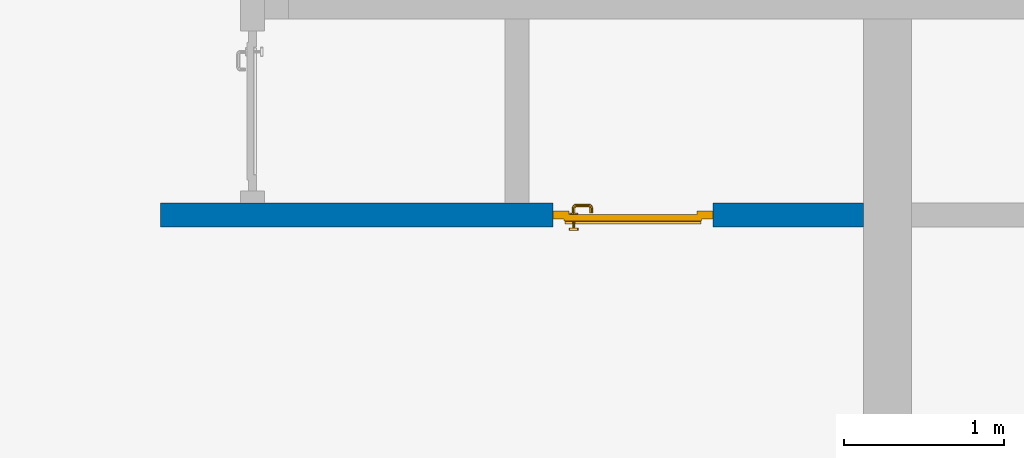
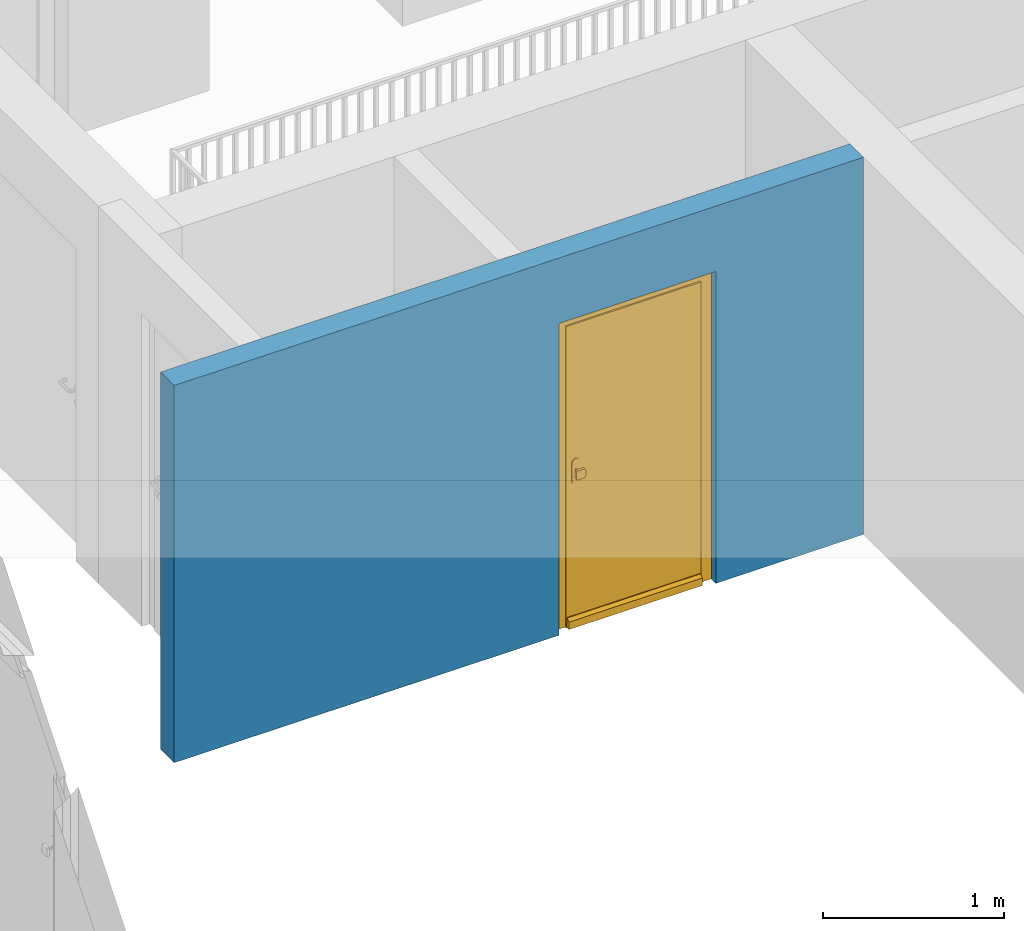
# One storey, part 2 of 54: 1 door, 1 wall, 1 opening.
"""IFC4 building model written with IfcOpenShell, lengths in metres."""

from ifc_helpers import new_model, entity, si_unit, converted_unit, derived_unit, direction, frame, origin_with_axes, place, context, subcontext, project, spatial, polygons, source, transform, mapped, material, type_object, element, fill, save


model = new_model("IFC4")

# Units and contexts
model_context = context("Model", 3, precision=1e-05, world=origin_with_axes(), true_north=direction((0.0, 1.0)))
body_context = subcontext(model_context, "Body", "Model", "MODEL_VIEW")
ifc_project = project(units=[si_unit("LENGTHUNIT", "METRE"), si_unit("AREAUNIT", "SQUARE_METRE"), si_unit("VOLUMEUNIT", "CUBIC_METRE"), converted_unit("PLANEANGLEUNIT", "DEGREE", entity("IfcPlaneAngleMeasure", 0.0174532925199), si_unit("PLANEANGLEUNIT", "RADIAN"), dimensions=[0, 0, 0, 0, 0, 0, 0]), converted_unit("TIMEUNIT", "Year", entity("IfcTimeMeasure", 31556926.0), si_unit("TIMEUNIT", "SECOND"), dimensions=[0, 0, 1, 0, 0, 0, 0]), si_unit("MASSUNIT", "GRAM", prefix="KILO"), si_unit("THERMODYNAMICTEMPERATUREUNIT", "DEGREE_CELSIUS"), si_unit("LUMINOUSINTENSITYUNIT", "LUMEN"), si_unit("ENERGYUNIT", "JOULE", prefix="MEGA"), derived_unit("THERMALCONDUCTANCEUNIT", [(si_unit("POWERUNIT", "WATT"), 1), (si_unit("LENGTHUNIT", "METRE"), -1), (si_unit("THERMODYNAMICTEMPERATUREUNIT", "KELVIN"), -1)]), derived_unit("SPECIFICHEATCAPACITYUNIT", [(si_unit("ENERGYUNIT", "JOULE"), 1), (si_unit("MASSUNIT", "GRAM", prefix="KILO"), -1), (si_unit("THERMODYNAMICTEMPERATUREUNIT", "KELVIN"), -1)]), derived_unit("MASSDENSITYUNIT", [(si_unit("MASSUNIT", "GRAM", prefix="KILO"), 1), (si_unit("VOLUMEUNIT", "CUBIC_METRE"), -1)])], contexts=[model_context])

# Site, building, storey
site_placement = place(None, origin_with_axes())
site = spatial("IfcSite", under=ifc_project, at=site_placement, CompositionType="ELEMENT")
building_placement = place(site_placement, origin_with_axes())
building = spatial("IfcBuilding", under=site, at=building_placement, CompositionType="ELEMENT")
storey_placement = place(building_placement, frame((0.0, 0.0, 9.18), z_axis=(0.0, 0.0, 1.0), x_axis=(1.0, 0.0, 0.0)))
storey = spatial("IfcBuildingStorey", under=building, at=storey_placement, Name="3. Geschoss", CompositionType="ELEMENT", Elevation=9.18)

# Wall, opening, door
ifc_material = material()
wall_type = type_object("IfcWallType", Name="150", PredefinedType="NOTDEFINED")
wall_placement = place(storey_placement, frame((-5.7421993804, -4.12881223104, 0.0), z_axis=(0.0, 0.0, 1.0), x_axis=(1.0, 0.0, 0.0)))
wall = element("IfcWall", 1, at=wall_placement, inside=storey, type_object=wall_type, material=ifc_material, Name="Wand-002", PredefinedType="NOTDEFINED", context=body_context, shape_type="Tessellation", body=[
    polygons([(2.45, 0.15, 2.1), (2.45, 0.15, 0.0), (0.0, 0.15, 0.0), (0.0, 0.15, 2.54), (4.39, 0.15, 2.54), (4.39, 0.15, 0.0), (3.45, 0.15, 0.0), (3.45, 0.15, 2.1), (2.45, 0.05, 0.0), (2.45, 0.0, 2.1), (2.45, 0.0, 0.0), (0.0, 0.0, 0.0), (0.0, 0.0, 2.54), (4.39, 0.0, 2.54), (4.39, 0.0, 0.0), (3.45, 0.05, 0.0), (3.45, 0.0, 0.0), (3.45, 0.0, 2.1)], [[[1, 2, 3, 4, 5, 6, 7, 8]], [[9, 2, 1, 10, 11]], [[2, 9, 11, 12, 3]], [[4, 3, 12, 13]], [[5, 4, 13, 14]], [[14, 15, 6, 5]], [[16, 7, 6, 15, 17]], [[8, 7, 16, 17, 18]], [[1, 8, 18, 10]], [[12, 11, 10, 18, 17, 15, 14, 13]]], closed=True),
])
opening_placement = place(wall_placement, frame((2.95, 0.0, 0.0), z_axis=(0.0, 0.0, 1.0), x_axis=(1.0, 0.0, 0.0)))
opening = element("IfcOpeningElement", 2, at=opening_placement, cuts=wall, context=body_context, identifier="Reference", shape_type="Tessellation", body=[
    polygons([(0.5, 0.05, 0.0), (0.5, 0.05, 2.1), (0.5, -0.001, 2.1), (0.5, -0.001, 0.0), (0.5, 0.151, 0.0), (0.5, 0.151, 2.1), (-0.5, 0.05, 2.1), (-0.5, -0.001, 2.1), (-0.5, 0.151, 2.1), (-0.5, -0.001, 0.0), (-0.5, 0.05, 0.0), (-0.5, 0.151, 0.0)], [[[1, 2, 3, 4]], [[2, 1, 5, 6]], [[7, 8, 3, 2, 6, 9]], [[8, 10, 4, 3]], [[1, 4, 10, 11, 12, 5]], [[6, 5, 12, 9]], [[7, 11, 10, 8]], [[11, 7, 9, 12]]], closed=True),
])
door_type = type_object("IfcDoorType", Name="Eingang 01 1-Fl 26", OperationType="SINGLE_SWING_LEFT", PredefinedType="DOOR")
shared_shape = source(origin_with_axes(), body_context, "Body", "Tessellation", [
    polygons([(-0.5, -0.05, 0.0), (-0.5, -0.05, 2.1), (-0.5, -0.03, 2.1), (-0.5, -0.03, 0.0), (-0.4, -0.05, 0.0), (-0.4, -0.05, 2.0), (-0.1301, -0.05, 2.0), (-0.0001, -0.05, 2.0), (0.4, -0.05, 2.0), (0.4, -0.05, 0.0), (0.5, -0.05, 0.0), (0.5, -0.05, 2.1), (0.5, -0.03, 2.1), (0.5, -0.03, 0.0), (0.4, -0.03, 0.0), (0.4, -0.03, 2.0), (-0.0001, -0.03, 2.0), (-0.1301, -0.03, 2.0), (-0.4, -0.03, 2.0), (-0.4, -0.03, 0.0)], [[[1, 2, 3, 4]], [[1, 5, 6, 7, 8, 9, 10, 11, 12, 2]], [[2, 12, 13, 3]], [[4, 3, 13, 14, 15, 16, 17, 18, 19, 20]], [[5, 1, 4, 20]], [[6, 5, 20, 19]], [[7, 6, 19, 18]], [[8, 7, 18, 17]], [[9, 8, 17, 16]], [[10, 9, 16, 15]], [[11, 10, 15, 14]], [[12, 11, 14, 13]]], closed=True),
    polygons([(-0.5, -0.03, 0.0), (-0.5, -0.03, 2.1), (-0.5, 0.0, 2.1), (-0.5, 0.0, 0.0), (-0.43, -0.03, 0.0), (-0.43, -0.03, 2.03), (-0.1001, -0.03, 2.03), (-0.0301, -0.03, 2.03), (0.43, -0.03, 2.03), (0.43, -0.03, 0.0), (0.5, -0.03, 0.0), (0.5, -0.03, 2.1), (0.5, 0.0, 2.1), (0.5, 0.0, 0.0), (0.43, 0.0, 0.0), (0.43, 0.0, 2.03), (-0.0301, 0.0, 2.03), (-0.1001, 0.0, 2.03), (-0.43, 0.0, 2.03), (-0.43, 0.0, 0.0)], [[[1, 2, 3, 4]], [[1, 5, 6, 7, 8, 9, 10, 11, 12, 2]], [[2, 12, 13, 3]], [[4, 3, 13, 14, 15, 16, 17, 18, 19, 20]], [[5, 1, 4, 20]], [[6, 5, 20, 19]], [[7, 6, 19, 18]], [[8, 7, 18, 17]], [[9, 8, 17, 16]], [[10, 9, 16, 15]], [[11, 10, 15, 14]], [[12, 11, 14, 13]]], closed=True),
    polygons([(-0.43, 0.01, 0.0), (-0.43, 0.01, 2.03), (0.43, 0.01, 2.03), (0.43, 0.01, 0.0), (-0.43, -0.03, 0.0), (-0.43, -0.03, 2.03), (0.43, -0.03, 2.03), (0.43, -0.03, 0.0)], [[[1, 2, 3, 4]], [[1, 5, 6, 2]], [[2, 6, 7, 3]], [[3, 7, 8, 4]], [[4, 8, 5, 1]], [[8, 7, 6, 5]]], closed=True),
    polygons([(-0.425, 0.03, 0.0), (-0.425, 0.03, 0.05), (0.425, 0.03, 0.05), (0.425, 0.03, 0.0), (-0.425, 0.01, 0.0), (-0.425, 0.01, 0.07), (-0.425, 0.015, 0.07), (0.425, 0.015, 0.07), (0.425, 0.01, 0.07), (0.425, 0.01, 0.0)], [[[1, 2, 3, 4]], [[1, 5, 6, 7, 2]], [[2, 7, 8, 3]], [[4, 3, 8, 9, 10]], [[5, 1, 4, 10]], [[6, 5, 10, 9]], [[7, 6, 9, 8]]], closed=True),
    polygons([(0.3835, -0.04, 1.0733826859), (0.3835, -0.0399, 1.0733826859), (0.37, -0.0399, 1.077), (0.37, -0.04, 1.077), (0.393382685902, -0.04, 1.0635), (0.393382685902, -0.0399, 1.0635), (0.3835, -0.0301, 1.0733826859), (0.37, -0.0301, 1.077), (0.3565, -0.0399, 1.0733826859), (0.3565, -0.04, 1.0733826859), (0.346617314098, -0.04, 1.0635), (0.343, -0.04, 1.05), (0.346617314098, -0.04, 1.0365), (0.3565, -0.04, 1.0266173141), (0.37, -0.04, 1.023), (0.3835, -0.04, 1.0266173141), (0.393382685902, -0.04, 1.0365), (0.397, -0.04, 1.05), (0.397, -0.0399, 1.05), (0.393382685902, -0.0301, 1.0635), (0.3835, -0.03, 1.0733826859), (0.37, -0.03, 1.077), (0.3565, -0.0301, 1.0733826859), (0.346617314098, -0.0399, 1.0635), (0.343, -0.0399, 1.05), (0.346617314098, -0.0399, 1.0365), (0.3565, -0.0399, 1.0266173141), (0.37, -0.0399, 1.023), (0.3835, -0.0399, 1.0266173141), (0.393382685902, -0.0399, 1.0365), (0.397, -0.0301, 1.05), (0.393382685902, -0.03, 1.0635), (0.397, -0.03, 1.05), (0.393382685902, -0.03, 1.0365), (0.3835, -0.03, 1.0266173141), (0.37, -0.03, 1.023), (0.3565, -0.03, 1.0266173141), (0.346617314098, -0.03, 1.0365), (0.343, -0.03, 1.05), (0.346617314098, -0.03, 1.0635), (0.3565, -0.03, 1.0733826859), (0.346617314098, -0.0301, 1.0635), (0.343, -0.0301, 1.05), (0.346617314098, -0.0301, 1.0365), (0.3565, -0.0301, 1.0266173141), (0.37, -0.0301, 1.023), (0.3835, -0.0301, 1.0266173141), (0.393382685902, -0.0301, 1.0365)], [[[1, 2, 3, 4]], [[5, 6, 2, 1]], [[2, 7, 8, 3]], [[4, 3, 9, 10]], [[4, 10, 11, 12, 13, 14, 15, 16, 17, 18, 5, 1]], [[18, 19, 6, 5]], [[6, 20, 7, 2]], [[7, 21, 22, 8]], [[3, 8, 23, 9]], [[10, 9, 24, 11]], [[11, 24, 25, 12]], [[12, 25, 26, 13]], [[13, 26, 27, 14]], [[14, 27, 28, 15]], [[15, 28, 29, 16]], [[16, 29, 30, 17]], [[17, 30, 19, 18]], [[19, 31, 20, 6]], [[20, 32, 21, 7]], [[22, 21, 32, 33, 34, 35, 36, 37, 38, 39, 40, 41]], [[8, 22, 41, 23]], [[9, 23, 42, 24]], [[24, 42, 43, 25]], [[25, 43, 44, 26]], [[26, 44, 45, 27]], [[27, 45, 46, 28]], [[28, 46, 47, 29]], [[29, 47, 48, 30]], [[30, 48, 31, 19]], [[31, 33, 32, 20]], [[48, 34, 33, 31]], [[47, 35, 34, 48]], [[46, 36, 35, 47]], [[45, 37, 36, 46]], [[44, 38, 37, 45]], [[43, 39, 38, 44]], [[42, 40, 39, 43]], [[23, 41, 40, 42]]], closed=True),
    polygons([(0.362532169224, -0.04, 0.959692280177), (0.363279754556, -0.04, 0.961639806549), (0.35655, -0.04, 0.973296083362), (0.346703916638, -0.04, 0.96345), (0.365, -0.04, 0.952886751346), (0.365, -0.04, 0.9544), (0.362532169224, -0.039, 0.959692280177), (0.363279754556, -0.039, 0.961639806549), (0.364624817685, -0.039, 0.965143815798), (0.364624817685, -0.04, 0.965143815798), (0.37, -0.04, 0.967425445323), (0.37, -0.04, 0.9769), (0.346617314098, -0.04, 0.9635), (0.3565, -0.04, 0.973382685902), (0.365, -0.04, 0.95), (0.3431, -0.04, 0.95), (0.365, -0.04, 0.947113248654), (0.365, -0.04, 0.941339745962), (0.365, -0.04, 0.9375), (0.365, -0.039, 0.9375), (0.365, -0.039, 0.941339745962), (0.365, -0.039, 0.947113248654), (0.365, -0.039, 0.95), (0.365, -0.039, 0.952886751346), (0.365, -0.039, 0.9544), (0.347569942042, -0.039, 0.96295), (0.35705, -0.039, 0.972430057958), (0.37, -0.039, 0.9759), (0.37, -0.039, 0.967425445323), (0.375375182315, -0.04, 0.965143815798), (0.376720245444, -0.04, 0.961639806549), (0.38345, -0.04, 0.973296083362), (0.37, -0.04, 0.977), (0.343, -0.04, 0.95), (0.346617314098, -0.0399, 0.9635), (0.3565, -0.0399, 0.973382685902), (0.346703916638, -0.04, 0.93655), (0.35655, -0.04, 0.926703916638), (0.37, -0.04, 0.9231), (0.37, -0.04, 0.9325), (0.366464466094, -0.04, 0.933964466094), (0.366464466094, -0.039, 0.933964466094), (0.37, -0.039, 0.9241), (0.35705, -0.039, 0.927569942042), (0.37, -0.039, 0.9325), (0.347569942042, -0.039, 0.93705), (0.3441, -0.039, 0.95), (0.347483339502, -0.039, 0.963), (0.357, -0.039, 0.972516660498), (0.37, -0.039, 0.976), (0.375375182315, -0.039, 0.965143815798), (0.38295, -0.039, 0.972430057958), (0.376720245444, -0.039, 0.961639806549), (0.377467830776, -0.039, 0.959692280177), (0.377467830776, -0.04, 0.959692280177), (0.375, -0.04, 0.9544), (0.375, -0.04, 0.952886751346), (0.393296083362, -0.04, 0.96345), (0.3835, -0.04, 0.973382685902), (0.37, -0.0399, 0.977), (0.346617314098, -0.04, 0.9365), (0.343, -0.0399, 0.95), (0.346617314098, -0.0301, 0.9635), (0.3565, -0.0301, 0.973382685902), (0.3565, -0.04, 0.926617314098), (0.37, -0.04, 0.923), (0.38345, -0.04, 0.926703916638), (0.375, -0.04, 0.941339745962), (0.375, -0.04, 0.9375), (0.373535533906, -0.04, 0.933964466094), (0.37, -0.039, 0.924), (0.357, -0.039, 0.927483339502), (0.38295, -0.039, 0.927569942042), (0.373535533906, -0.039, 0.933964466094), (0.375, -0.039, 0.9375), (0.375, -0.039, 0.941339745962), (0.347483339502, -0.039, 0.937), (0.344, -0.039, 0.95), (0.347483339502, -0.0389, 0.963), (0.357, -0.0389, 0.972516660498), (0.37, -0.0389, 0.976), (0.383, -0.039, 0.972516660498), (0.392430057958, -0.039, 0.96295), (0.375, -0.039, 0.952886751346), (0.375, -0.039, 0.9544), (0.375, -0.039, 0.95), (0.375, -0.039, 0.947113248654), (0.375, -0.04, 0.947113248654), (0.375, -0.04, 0.95), (0.3969, -0.04, 0.95), (0.393382685902, -0.04, 0.9635), (0.3835, -0.0399, 0.973382685902), (0.37, -0.0301, 0.977), (0.346617314098, -0.0399, 0.9365), (0.343, -0.0301, 0.95), (0.346617314098, -0.03, 0.9635), (0.3565, -0.03, 0.973382685902), (0.3565, -0.0399, 0.926617314098), (0.3835, -0.04, 0.926617314098), (0.37, -0.0399, 0.923), (0.393296083362, -0.04, 0.93655), (0.383, -0.039, 0.927483339502), (0.37, -0.0389, 0.924), (0.357, -0.0389, 0.927483339502), (0.392430057958, -0.039, 0.93705), (0.347483339502, -0.0389, 0.937), (0.344, -0.0389, 0.95), (0.347483339502, -0.0301, 0.963), (0.357, -0.0301, 0.972516660498), (0.37, -0.0301, 0.976), (0.383, -0.0389, 0.972516660498), (0.392516660498, -0.039, 0.963), (0.3959, -0.039, 0.95), (0.397, -0.04, 0.95), (0.393382685902, -0.0399, 0.9635), (0.3835, -0.0301, 0.973382685902), (0.37, -0.03, 0.977), (0.346617314098, -0.0301, 0.9365), (0.343, -0.03, 0.95), (0.346703916638, -0.03, 0.96345), (0.35655, -0.03, 0.973296083362), (0.3565, -0.0301, 0.926617314098), (0.393382685902, -0.04, 0.9365), (0.3835, -0.0399, 0.926617314098), (0.37, -0.0301, 0.923), (0.392516660498, -0.039, 0.937), (0.383, -0.0389, 0.927483339502), (0.37, -0.0301, 0.924), (0.357, -0.0301, 0.927483339502), (0.347483339502, -0.0301, 0.937), (0.344, -0.0301, 0.95), (0.347483339502, -0.03, 0.963), (0.357, -0.03, 0.972516660498), (0.37, -0.03, 0.976), (0.383, -0.0301, 0.972516660498), (0.392516660498, -0.0389, 0.963), (0.396, -0.039, 0.95), (0.397, -0.0399, 0.95), (0.393382685902, -0.0301, 0.9635), (0.3835, -0.03, 0.973382685902), (0.37, -0.03, 0.9769), (0.346617314098, -0.03, 0.9365), (0.3431, -0.03, 0.95), (0.347396736961, -0.03, 0.96305), (0.35695, -0.03, 0.972603263039), (0.3565, -0.03, 0.926617314098), (0.393382685902, -0.0399, 0.9365), (0.3835, -0.0301, 0.926617314098), (0.37, -0.03, 0.923), (0.392516660498, -0.0389, 0.937), (0.383, -0.0301, 0.927483339502), (0.37, -0.03, 0.924), (0.357, -0.03, 0.927483339502), (0.347483339502, -0.03, 0.937), (0.344, -0.03, 0.95), (0.37, -0.03, 0.9761), (0.383, -0.03, 0.972516660498), (0.392516660498, -0.0301, 0.963), (0.396, -0.0389, 0.95), (0.397, -0.0301, 0.95), (0.393382685902, -0.03, 0.9635), (0.38345, -0.03, 0.973296083362), (0.346703916638, -0.03, 0.93655), (0.3439, -0.03, 0.95), (0.35655, -0.03, 0.926703916638), (0.393382685902, -0.0301, 0.9365), (0.3835, -0.03, 0.926617314098), (0.37, -0.03, 0.9231), (0.392516660498, -0.0301, 0.937), (0.383, -0.03, 0.927483339502), (0.37, -0.03, 0.9239), (0.35695, -0.03, 0.927396736961), (0.347396736961, -0.03, 0.93695), (0.38305, -0.03, 0.972603263039), (0.392516660498, -0.03, 0.963), (0.396, -0.0301, 0.95), (0.397, -0.03, 0.95), (0.393296083362, -0.03, 0.96345), (0.393382685902, -0.03, 0.9365), (0.38345, -0.03, 0.926703916638), (0.392516660498, -0.03, 0.937), (0.38305, -0.03, 0.927396736961), (0.392603263039, -0.03, 0.96305), (0.396, -0.03, 0.95), (0.3969, -0.03, 0.95), (0.393296083362, -0.03, 0.93655), (0.392603263039, -0.03, 0.93695), (0.3961, -0.03, 0.95)], [[[1, 2, 3, 4, 5, 6]], [[1, 7, 8, 9, 10, 2]], [[10, 11, 12, 3, 2]], [[13, 4, 3, 14]], [[15, 5, 4, 16]], [[6, 5, 15, 17, 18, 19, 20, 21, 22, 23, 24, 25]], [[6, 25, 7, 1]], [[7, 25, 24, 26, 27, 8]], [[9, 8, 27, 28, 29]], [[10, 9, 29, 11]], [[30, 31, 32, 12, 11]], [[14, 3, 12, 33]], [[34, 16, 4, 13]], [[35, 13, 14, 36]], [[17, 15, 16, 37]], [[18, 17, 37, 38]], [[38, 39, 40, 41, 19, 18]], [[19, 41, 42, 20]], [[43, 44, 21, 20, 42, 45]], [[22, 21, 44, 46]], [[23, 22, 46, 47]], [[24, 23, 47, 26]], [[26, 48, 49, 27]], [[27, 49, 50, 28]], [[51, 29, 28, 52, 53]], [[11, 29, 51, 30]], [[30, 51, 53, 54, 55, 31]], [[55, 56, 57, 58, 32, 31]], [[33, 12, 32, 59]], [[36, 14, 33, 60]], [[61, 37, 16, 34]], [[62, 34, 13, 35]], [[63, 35, 36, 64]], [[65, 38, 37, 61]], [[66, 39, 38, 65]], [[39, 67, 68, 69, 70, 40]], [[41, 40, 45, 42]], [[43, 71, 72, 44]], [[73, 43, 45, 74, 75, 76]], [[44, 72, 77, 46]], [[46, 77, 78, 47]], [[47, 78, 48, 26]], [[48, 79, 80, 49]], [[49, 80, 81, 50]], [[28, 50, 82, 52]], [[54, 53, 52, 83, 84, 85]], [[55, 54, 85, 56]], [[85, 84, 86, 87, 76, 75, 69, 68, 88, 89, 57, 56]], [[57, 89, 90, 58]], [[59, 32, 58, 91]], [[60, 33, 59, 92]], [[64, 36, 60, 93]], [[94, 61, 34, 62]], [[95, 62, 35, 63]], [[96, 63, 64, 97]], [[98, 65, 61, 94]], [[99, 67, 39, 66]], [[100, 66, 65, 98]], [[88, 68, 67, 101]], [[70, 69, 75, 74]], [[40, 70, 74, 45]], [[73, 102, 71, 43]], [[71, 103, 104, 72]], [[76, 87, 105, 73]], [[72, 104, 106, 77]], [[77, 106, 107, 78]], [[78, 107, 79, 48]], [[79, 108, 109, 80]], [[80, 109, 110, 81]], [[50, 81, 111, 82]], [[52, 82, 112, 83]], [[86, 84, 83, 113]], [[87, 86, 113, 105]], [[89, 88, 101, 90]], [[91, 58, 90, 114]], [[92, 59, 91, 115]], [[93, 60, 92, 116]], [[97, 64, 93, 117]], [[118, 94, 62, 95]], [[119, 95, 63, 96]], [[120, 96, 97, 121]], [[122, 98, 94, 118]], [[123, 101, 67, 99]], [[124, 99, 66, 100]], [[125, 100, 98, 122]], [[105, 126, 102, 73]], [[102, 127, 103, 71]], [[103, 128, 129, 104]], [[104, 129, 130, 106]], [[106, 130, 131, 107]], [[107, 131, 108, 79]], [[108, 132, 133, 109]], [[109, 133, 134, 110]], [[81, 110, 135, 111]], [[82, 111, 136, 112]], [[83, 112, 137, 113]], [[113, 137, 126, 105]], [[114, 90, 101, 123]], [[115, 91, 114, 138]], [[116, 92, 115, 139]], [[117, 93, 116, 140]], [[121, 97, 117, 141]], [[142, 118, 95, 119]], [[143, 119, 96, 120]], [[144, 120, 121, 145]], [[146, 122, 118, 142]], [[147, 123, 99, 124]], [[148, 124, 100, 125]], [[149, 125, 122, 146]], [[126, 150, 127, 102]], [[127, 151, 128, 103]], [[128, 152, 153, 129]], [[129, 153, 154, 130]], [[130, 154, 155, 131]], [[131, 155, 132, 108]], [[132, 144, 145, 133]], [[133, 145, 156, 134]], [[110, 134, 157, 135]], [[111, 135, 158, 136]], [[112, 136, 159, 137]], [[137, 159, 150, 126]], [[138, 114, 123, 147]], [[139, 115, 138, 160]], [[140, 116, 139, 161]], [[141, 117, 140, 162]], [[145, 121, 141, 156]], [[163, 142, 119, 143]], [[164, 143, 120, 144]], [[165, 146, 142, 163]], [[166, 147, 124, 148]], [[167, 148, 125, 149]], [[168, 149, 146, 165]], [[150, 169, 151, 127]], [[151, 170, 152, 128]], [[152, 171, 172, 153]], [[153, 172, 173, 154]], [[154, 173, 164, 155]], [[155, 164, 144, 132]], [[134, 156, 174, 157]], [[135, 157, 175, 158]], [[136, 158, 176, 159]], [[159, 176, 169, 150]], [[160, 138, 147, 166]], [[161, 139, 160, 177]], [[162, 140, 161, 178]], [[156, 141, 162, 174]], [[173, 163, 143, 164]], [[172, 165, 163, 173]], [[179, 166, 148, 167]], [[180, 167, 149, 168]], [[171, 168, 165, 172]], [[169, 181, 170, 151]], [[170, 182, 171, 152]], [[157, 174, 183, 175]], [[158, 175, 184, 176]], [[176, 184, 181, 169]], [[177, 160, 166, 179]], [[178, 161, 177, 185]], [[174, 162, 178, 183]], [[186, 179, 167, 180]], [[182, 180, 168, 171]], [[181, 187, 182, 170]], [[175, 183, 188, 184]], [[184, 188, 187, 181]], [[185, 177, 179, 186]], [[183, 178, 185, 188]], [[187, 186, 180, 182]], [[188, 185, 186, 187]]], closed=True),
    polygons([(0.38, -0.04, 1.05), (0.38, -0.0709849140336, 1.05), (0.377071067812, -0.070696439392, 1.04292893219), (0.377071067812, -0.04, 1.04292893219), (0.377071067812, -0.04, 1.05707106781), (0.377071067812, -0.070696439392, 1.05707106781), (0.378277987014, -0.0796420579258, 1.05), (0.375518993221, -0.0784992452783, 1.04292893219), (0.37, -0.07, 1.04), (0.37, -0.04, 1.04), (0.37, -0.04, 1.06), (0.37, -0.07, 1.06), (0.375518993221, -0.0784992452783, 1.05707106781), (0.372816199938, -0.0878161999379, 1.05), (0.370704557509, -0.0857045575088, 1.04292893219), (0.368858192988, -0.0757402514855, 1.04), (0.362928932188, -0.069303560608, 1.04292893219), (0.362928932188, -0.04, 1.04292893219), (0.362928932188, -0.04, 1.05707106781), (0.362928932188, -0.069303560608, 1.05707106781), (0.368858192988, -0.0757402514855, 1.06), (0.370704557509, -0.0857045575088, 1.05707106781), (0.364642057926, -0.0932779870137, 1.05), (0.363499245278, -0.0905189932208, 1.04292893219), (0.365606601718, -0.0806066017178, 1.04), (0.362197392755, -0.0729812576926, 1.04292893219), (0.36, -0.0690150859664, 1.05), (0.36, -0.04, 1.05), (0.362197392755, -0.0729812576926, 1.05707106781), (0.365606601718, -0.0806066017178, 1.06), (0.363499245278, -0.0905189932208, 1.05707106781), (0.355984914034, -0.095, 1.05), (0.355696439392, -0.0920710678119, 1.04292893219), (0.360740251485, -0.0838581929877, 1.04), (0.360508645927, -0.0755086459268, 1.04292893219), (0.359438398962, -0.0718384450452, 1.05), (0.360508645927, -0.0755086459268, 1.05707106781), (0.360740251485, -0.0838581929877, 1.06), (0.355696439392, -0.0920710678119, 1.05707106781), (0.274015085966, -0.095, 1.05), (0.274303560608, -0.0920710678119, 1.04292893219), (0.355, -0.085, 1.04), (0.357981257693, -0.0771973927545, 1.04292893219), (0.358397003498, -0.0733970034977, 1.05), (0.357981257693, -0.0771973927545, 1.05707106781), (0.355, -0.085, 1.06), (0.274303560608, -0.0920710678119, 1.05707106781), (0.265357942074, -0.0932779870137, 1.05), (0.266500754722, -0.0905189932208, 1.04292893219), (0.275, -0.085, 1.04), (0.354303560608, -0.0779289321881, 1.04292893219), (0.356838445045, -0.0744383989617, 1.05), (0.354303560608, -0.0779289321881, 1.05707106781), (0.275, -0.085, 1.06), (0.266500754722, -0.0905189932208, 1.05707106781), (0.257183800062, -0.0878161999379, 1.05), (0.259295442491, -0.0857045575088, 1.04292893219), (0.269259748515, -0.0838581929877, 1.04), (0.275696439392, -0.0779289321881, 1.04292893219), (0.354015085966, -0.075, 1.05), (0.275696439392, -0.0779289321881, 1.05707106781), (0.269259748515, -0.0838581929877, 1.06), (0.259295442491, -0.0857045575088, 1.05707106781), (0.251722012986, -0.0796420579258, 1.05), (0.254481006779, -0.0784992452783, 1.04292893219), (0.264393398282, -0.0806066017178, 1.04), (0.272018742307, -0.0771973927545, 1.04292893219), (0.275984914034, -0.075, 1.05), (0.272018742307, -0.0771973927545, 1.05707106781), (0.264393398282, -0.0806066017178, 1.06), (0.254481006779, -0.0784992452783, 1.05707106781), (0.25, -0.0709849140336, 1.05), (0.252928932188, -0.070696439392, 1.04292893219), (0.261141807012, -0.0757402514855, 1.04), (0.269491354073, -0.0755086459268, 1.04292893219), (0.273161554955, -0.0744383989617, 1.05), (0.269491354073, -0.0755086459268, 1.05707106781), (0.261141807012, -0.0757402514855, 1.06), (0.252928932188, -0.070696439392, 1.05707106781), (0.25, -0.04, 1.05), (0.252928932188, -0.04, 1.04292893219), (0.26, -0.07, 1.04), (0.267802607245, -0.0729812576926, 1.04292893219), (0.271602996502, -0.0733970034977, 1.05), (0.267802607245, -0.0729812576926, 1.05707106781), (0.26, -0.07, 1.06), (0.252928932188, -0.04, 1.05707106781), (0.26, -0.04, 1.06), (0.267071067812, -0.04, 1.05707106781), (0.27, -0.04, 1.05), (0.267071067812, -0.04, 1.04292893219), (0.26, -0.04, 1.04), (0.267071067812, -0.069303560608, 1.04292893219), (0.270561601038, -0.0718384450452, 1.05), (0.267071067812, -0.069303560608, 1.05707106781), (0.27, -0.0690150859664, 1.05)], [[[1, 2, 3, 4]], [[5, 6, 2, 1]], [[2, 7, 8, 3]], [[4, 3, 9, 10]], [[11, 12, 6, 5]], [[6, 13, 7, 2]], [[7, 14, 15, 8]], [[3, 8, 16, 9]], [[10, 9, 17, 18]], [[19, 20, 12, 11]], [[12, 21, 13, 6]], [[13, 22, 14, 7]], [[14, 23, 24, 15]], [[8, 15, 25, 16]], [[9, 16, 26, 17]], [[18, 17, 27, 28]], [[28, 27, 20, 19]], [[20, 29, 21, 12]], [[21, 30, 22, 13]], [[22, 31, 23, 14]], [[23, 32, 33, 24]], [[15, 24, 34, 25]], [[16, 25, 35, 26]], [[17, 26, 36, 27]], [[27, 36, 29, 20]], [[29, 37, 30, 21]], [[30, 38, 31, 22]], [[31, 39, 32, 23]], [[32, 40, 41, 33]], [[24, 33, 42, 34]], [[25, 34, 43, 35]], [[26, 35, 44, 36]], [[36, 44, 37, 29]], [[37, 45, 38, 30]], [[38, 46, 39, 31]], [[39, 47, 40, 32]], [[40, 48, 49, 41]], [[33, 41, 50, 42]], [[34, 42, 51, 43]], [[35, 43, 52, 44]], [[44, 52, 45, 37]], [[45, 53, 46, 38]], [[46, 54, 47, 39]], [[47, 55, 48, 40]], [[48, 56, 57, 49]], [[41, 49, 58, 50]], [[42, 50, 59, 51]], [[43, 51, 60, 52]], [[52, 60, 53, 45]], [[53, 61, 54, 46]], [[54, 62, 55, 47]], [[55, 63, 56, 48]], [[56, 64, 65, 57]], [[49, 57, 66, 58]], [[50, 58, 67, 59]], [[51, 59, 68, 60]], [[60, 68, 61, 53]], [[61, 69, 62, 54]], [[62, 70, 63, 55]], [[63, 71, 64, 56]], [[64, 72, 73, 65]], [[57, 65, 74, 66]], [[58, 66, 75, 67]], [[59, 67, 76, 68]], [[68, 76, 69, 61]], [[69, 77, 70, 62]], [[70, 78, 71, 63]], [[71, 79, 72, 64]], [[72, 80, 81, 73]], [[65, 73, 82, 74]], [[66, 74, 83, 75]], [[67, 75, 84, 76]], [[76, 84, 77, 69]], [[77, 85, 78, 70]], [[78, 86, 79, 71]], [[79, 87, 80, 72]], [[80, 87, 88, 89, 90, 91, 92, 81]], [[73, 81, 92, 82]], [[74, 82, 93, 83]], [[75, 83, 94, 84]], [[84, 94, 85, 77]], [[85, 95, 86, 78]], [[86, 88, 87, 79]], [[95, 89, 88, 86]], [[96, 90, 89, 95]], [[93, 91, 90, 96]], [[82, 92, 91, 93]], [[83, 93, 96, 94]], [[94, 96, 95, 85]]], closed=False),
    polygons([(0.364696699141, 0.015, 1.04469669914), (0.37, 0.015, 1.0425), (0.375303300859, 0.015, 1.04469669914), (0.3775, 0.015, 1.05), (0.375303300859, 0.015, 1.05530330086), (0.37, 0.015, 1.0575), (0.364696699141, 0.015, 1.05530330086), (0.3625, 0.015, 1.05), (0.364696699141, 0.055, 1.04469669914), (0.37, 0.055, 1.0425), (0.375303300859, 0.055, 1.04469669914), (0.3775, 0.055, 1.05), (0.375303300859, 0.055, 1.05530330086), (0.37, 0.055, 1.0575), (0.364696699141, 0.055, 1.05530330086), (0.3625, 0.055, 1.05)], [[[1, 2, 3, 4, 5, 6, 7, 8]], [[2, 1, 9, 10]], [[3, 2, 10, 11]], [[4, 3, 11, 12]], [[5, 4, 12, 13]], [[6, 5, 13, 14]], [[7, 6, 14, 15]], [[8, 7, 15, 16]], [[1, 8, 16, 9]], [[9, 16, 15, 14, 13, 12, 11, 10]]], closed=True),
    polygons([(0.395, 0.01, 0.975), (0.393096988313, 0.01, 0.965432914191), (0.393096988313, 0.015, 0.965432914191), (0.395, 0.015, 0.975), (0.395, 0.01, 1.1), (0.393096988313, 0.01, 1.10956708581), (0.38767766953, 0.01, 1.11767766953), (0.379567085809, 0.01, 1.12309698831), (0.37, 0.01, 1.125), (0.360432914191, 0.01, 1.12309698831), (0.35232233047, 0.01, 1.11767766953), (0.346903011687, 0.01, 1.10956708581), (0.345, 0.01, 1.1), (0.345, 0.01, 0.975), (0.346903011687, 0.01, 0.965432914191), (0.35232233047, 0.01, 0.95732233047), (0.360432914191, 0.01, 0.951903011687), (0.37, 0.01, 0.95), (0.379567085809, 0.01, 0.951903011687), (0.38767766953, 0.01, 0.95732233047), (0.38767766953, 0.015, 0.95732233047), (0.379567085809, 0.015, 0.951903011687), (0.37, 0.015, 0.95), (0.360432914191, 0.015, 0.951903011687), (0.35232233047, 0.015, 0.95732233047), (0.346903011687, 0.015, 0.965432914191), (0.345, 0.015, 0.975), (0.345, 0.015, 1.1), (0.346903011687, 0.015, 1.10956708581), (0.35232233047, 0.015, 1.11767766953), (0.360432914191, 0.015, 1.12309698831), (0.37, 0.015, 1.125), (0.379567085809, 0.015, 1.12309698831), (0.38767766953, 0.015, 1.11767766953), (0.393096988313, 0.015, 1.10956708581), (0.395, 0.015, 1.1)], [[[1, 2, 3, 4]], [[1, 5, 6, 7, 8, 9, 10, 11, 12, 13, 14, 15, 16, 17, 18, 19, 20, 2]], [[2, 20, 21, 3]], [[4, 3, 21, 22, 23, 24, 25, 26, 27, 28, 29, 30, 31, 32, 33, 34, 35, 36]], [[5, 1, 4, 36]], [[6, 5, 36, 35]], [[7, 6, 35, 34]], [[8, 7, 34, 33]], [[9, 8, 33, 32]], [[10, 9, 32, 31]], [[11, 10, 31, 30]], [[12, 11, 30, 29]], [[13, 12, 29, 28]], [[14, 13, 28, 27]], [[15, 14, 27, 26]], [[16, 15, 26, 25]], [[17, 16, 25, 24]], [[18, 17, 24, 23]], [[19, 18, 23, 22]], [[20, 19, 22, 21]]], closed=True),
    polygons([(0.39, 0.055, 1.08), (0.395, 0.055, 1.07866025404), (0.395, 0.07, 1.07866025404), (0.39, 0.07, 1.08), (0.35, 0.055, 1.08), (0.345, 0.055, 1.07866025404), (0.341339745962, 0.055, 1.075), (0.34, 0.055, 1.07), (0.34, 0.055, 1.03), (0.341339745962, 0.055, 1.025), (0.345, 0.055, 1.02133974596), (0.35, 0.055, 1.02), (0.39, 0.055, 1.02), (0.395, 0.055, 1.02133974596), (0.398660254038, 0.055, 1.025), (0.4, 0.055, 1.03), (0.4, 0.055, 1.07), (0.398660254038, 0.055, 1.075), (0.398660254038, 0.07, 1.075), (0.4, 0.07, 1.07), (0.4, 0.07, 1.03), (0.398660254038, 0.07, 1.025), (0.395, 0.07, 1.02133974596), (0.39, 0.07, 1.02), (0.35, 0.07, 1.02), (0.345, 0.07, 1.02133974596), (0.341339745962, 0.07, 1.025), (0.34, 0.07, 1.03), (0.34, 0.07, 1.07), (0.341339745962, 0.07, 1.075), (0.345, 0.07, 1.07866025404), (0.35, 0.07, 1.08)], [[[1, 2, 3, 4]], [[1, 5, 6, 7, 8, 9, 10, 11, 12, 13, 14, 15, 16, 17, 18, 2]], [[2, 18, 19, 3]], [[4, 3, 19, 20, 21, 22, 23, 24, 25, 26, 27, 28, 29, 30, 31, 32]], [[5, 1, 4, 32]], [[6, 5, 32, 31]], [[7, 6, 31, 30]], [[8, 7, 30, 29]], [[9, 8, 29, 28]], [[10, 9, 28, 27]], [[11, 10, 27, 26]], [[12, 11, 26, 25]], [[13, 12, 25, 24]], [[14, 13, 24, 23]], [[15, 14, 23, 22]], [[16, 15, 22, 21]], [[17, 16, 21, 20]], [[18, 17, 20, 19]]], closed=True),
])
door_placement = place(opening_placement, frame((0.4, 0.0, 0.0), z_axis=(0.0, 0.0, 1.0), x_axis=(-1.0, 0.0, 0.0)))
door = element("IfcDoor", 3, at=door_placement, inside=storey, type_object=door_type, OverallHeight=2.1, OverallWidth=1.0, PredefinedType="DOOR", context=body_context, shape_type="MappedRepresentation", body=[
    mapped(shared_shape, transform((0.4, -0.05, 0.0))),
])
fill(opening, door)

save(model, "model.ifc")
